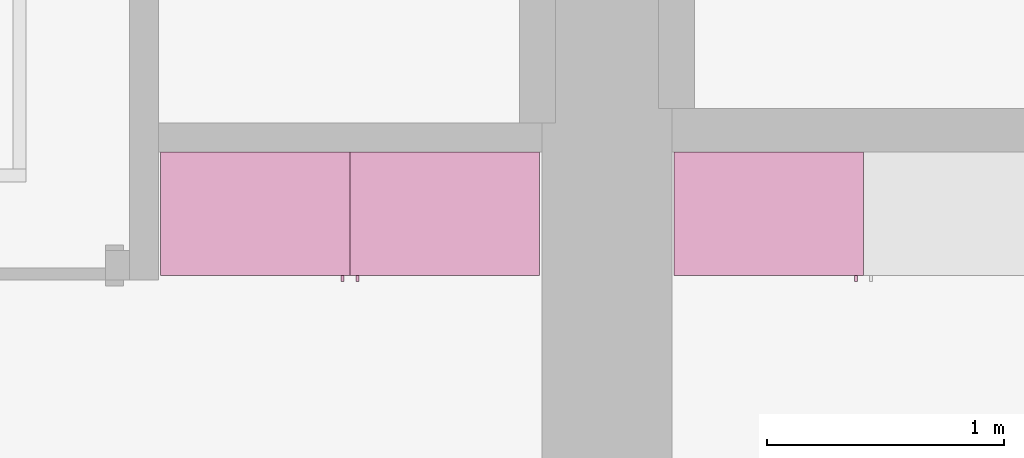
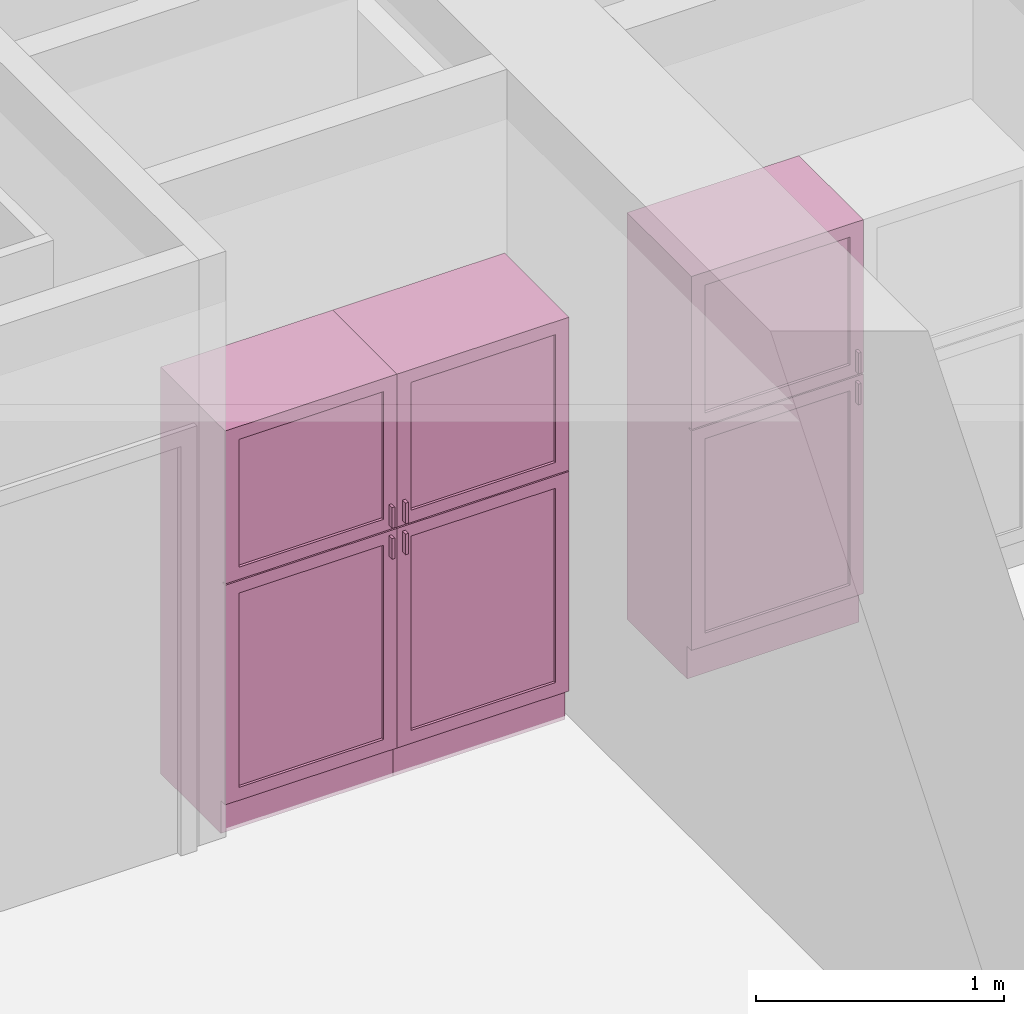
# One storey, part 14 of 16: 3 furnishings, 3 openings.
"""IFC2X3 building model written with IfcOpenShell, lengths in metres."""

import ifcopenshell
import ifcopenshell.guid

model = None  # the IFC model being written
_history = None  # IfcOwnerHistory: only IFC2X3 demands one
_inside = {}  # id of a spatial element -> (the spatial element, [elements in it])
_under = {}  # id of a project, library or spatial element -> (it, [spatial elements below it])
_declared = {}  # id of a project -> (the project, [libraries it declares])
_typed = {}  # id of a type object -> (the type object, [elements of that type])
_made_of = {}  # id of a material, layer set ... -> (it, [elements and type objects made of it])


def new_model(schema):
    """Start an empty IFC model of exactly this schema.

    Asked for "IFC4X3", IfcOpenShell would pick the latest addendum, in which some entities
    have other attributes; the version numbers below select the first issue.
    IFC2X3 requires an IfcOwnerHistory on every rooted entity: one is made here for all.
    """
    global model, _history
    if schema == "IFC4X3":
        model = ifcopenshell.file(schema_version=(4, 3, 0, 0))
    else:
        model = ifcopenshell.file(schema=schema)
    _inside.clear()
    _under.clear()
    _declared.clear()
    _typed.clear()
    _made_of.clear()
    _history = None
    if model.schema == "IFC2X3":
        org = make("IfcOrganization", Name="unknown")
        user = make(
            "IfcPersonAndOrganization",
            ThePerson=make("IfcPerson", FamilyName="unknown"),
            TheOrganization=org,
        )
        app = make(
            "IfcApplication",
            ApplicationDeveloper=org,
            Version="unknown",
            ApplicationFullName="unknown",
            ApplicationIdentifier="unknown",
        )
        _history = make(
            "IfcOwnerHistory",
            OwningUser=user,
            OwningApplication=app,
            ChangeAction="ADDED",
            CreationDate=0,
        )
    return model


def make(cls, **values):
    """One entity of the class cls with the attributes given. An attribute that is None is left unset."""
    return model.create_entity(
        cls, **{name: value for name, value in values.items() if value is not None}
    )


def entity(cls, *values):
    """Any entity or typed value of the class cls, its attributes in the order of the schema. None: left unset."""
    e = model.create_entity(cls)
    for i, value in enumerate(values):
        if value is not None:
            e[i] = value
    return e


def rooted(cls, **values):
    """An entity with a GlobalId (a new one), such as an element, a storey or a relation."""
    return make(cls, GlobalId=ifcopenshell.guid.new(), OwnerHistory=_history, **values)


def si_unit(unit_type, name, prefix=None):
    """IfcSIUnit, for example si_unit("LENGTHUNIT", "METRE", prefix="MILLI")."""
    return make("IfcSIUnit", UnitType=unit_type, Prefix=prefix, Name=name)


def converted_unit(unit_type, name, factor, base, dimensions=None, offset=None):
    """IfcConversionBasedUnit, such as the inch: factor (a typed value) times the base unit."""
    return make(
        "IfcConversionBasedUnit"
        if offset is None
        else "IfcConversionBasedUnitWithOffset",
        ConversionOffset=offset,
        Dimensions=None
        if dimensions is None
        else entity("IfcDimensionalExponents", *dimensions),
        UnitType=unit_type,
        Name=name,
        ConversionFactor=make(
            "IfcMeasureWithUnit", ValueComponent=factor, UnitComponent=base
        ),
    )


def assignment(units):
    """IfcUnitAssignment: the units of a project."""
    return None if units is None else make("IfcUnitAssignment", Units=units)


def point(xyz):
    """IfcCartesianPoint."""
    return None if xyz is None else make("IfcCartesianPoint", Coordinates=xyz)


def direction(xyz):
    """IfcDirection."""
    return None if xyz is None else make("IfcDirection", DirectionRatios=xyz)


def frame(location, z_axis=None, x_axis=None):
    """IfcAxis2Placement3D, a coordinate frame: its origin and axes. An axis left out is left unset."""
    return make(
        "IfcAxis2Placement3D",
        Location=point(location),
        Axis=direction(z_axis),
        RefDirection=direction(x_axis),
    )


def frame_2d(location, x_axis=None):
    """IfcAxis2Placement2D, a coordinate frame in the plane: its origin and x axis."""
    return make(
        "IfcAxis2Placement2D", Location=point(location), RefDirection=direction(x_axis)
    )


def origin():
    """The frame at (0, 0, 0) with its axes left unset."""
    return frame((0.0, 0.0, 0.0))


def origin_2d_with_axis():
    """The frame at (0, 0) in the plane with the x axis (1, 0) written out."""
    return frame_2d((0.0, 0.0), x_axis=(1.0, 0.0))


def place(relative_to, where):
    """IfcLocalPlacement: puts the frame where relative to a parent placement (None: the world)."""
    return make(
        "IfcLocalPlacement", PlacementRelTo=relative_to, RelativePlacement=where
    )


def context(
    kind, dimensions, precision=None, world=None, true_north=None, identifier=None
):
    """IfcGeometricRepresentationContext, for example the 3D "Model" context."""
    return make(
        "IfcGeometricRepresentationContext",
        ContextIdentifier=identifier,
        ContextType=kind,
        CoordinateSpaceDimension=dimensions,
        Precision=precision,
        WorldCoordinateSystem=world,
        TrueNorth=true_north,
    )


def project(units=None, contexts=None):
    """IfcProject with its units and contexts."""
    return rooted(
        "IfcProject",
        Name="project",
        RepresentationContexts=contexts,
        UnitsInContext=assignment(units),
    )


def spatial(cls, under=None, at=None, **own):
    """A site, building, storey or space (cls), placed at a placement, below another one or the project."""
    s = rooted(cls, ObjectPlacement=at, **own)
    if under is not None:
        _under.setdefault(under.id(), (under, []))[1].append(s)
    return s


def profile(cls, at=None, kind="AREA", **sizes):
    """A parametric profile (cls). Its sizes go by their IFC names, for example OverallWidth=200.0."""
    return make(cls, ProfileType=kind, Position=at, **sizes)


def rectangle(**sizes):
    """IfcRectangleProfileDef."""
    return profile("IfcRectangleProfileDef", **sizes)


def extrude(swept, where, along, depth):
    """IfcExtrudedAreaSolid: the profile swept, set in the frame where, extruded along a direction by depth."""
    return make(
        "IfcExtrudedAreaSolid",
        SweptArea=swept,
        Position=where,
        ExtrudedDirection=direction(along),
        Depth=depth,
    )


def faces_of(points, faces, orient=None, outer=None):
    """IfcFace entities. A face is a list of loops; a loop is a list of indices into points, from 0.

    orient and outer hold one flag for each loop. By default every Orientation is true, the
    first loop of a face is its IfcFaceOuterBound and the others are IfcFaceBound.
    """
    made = []
    for i, loops in enumerate(faces):
        bounds = []
        for j, loop in enumerate(loops):
            is_outer = j == 0 if outer is None else outer[i][j]
            bounds.append(
                make(
                    "IfcFaceOuterBound" if is_outer else "IfcFaceBound",
                    Bound=make("IfcPolyLoop", Polygon=[points[k] for k in loop]),
                    Orientation=True if orient is None else orient[i][j],
                )
            )
        made.append(make("IfcFace", Bounds=bounds))
    return made


def face_set(faces, orient=None, outer=None):
    """The faces of one IfcConnectedFaceSet. surface_model builds it on its shared points."""
    return ("IfcConnectedFaceSet", faces, orient, outer)


def surface_model(cls, points, shells):
    """IfcFaceBasedSurfaceModel or IfcShellBasedSurfaceModel (cls): surfaces that need not close."""
    shared = [point(p) for p in points]
    made = [make(c, CfsFaces=faces_of(shared, fs, o, b)) for c, fs, o, b in shells]
    if cls == "IfcFaceBasedSurfaceModel":
        return make(cls, FbsmFaces=made)
    return make(cls, SbsmBoundary=made)


def shape(context_of_items, identifier, shape_type, items):
    """IfcShapeRepresentation: the items that make up one representation, for example the "Body"."""
    return make(
        "IfcShapeRepresentation",
        ContextOfItems=context_of_items,
        RepresentationIdentifier=identifier,
        RepresentationType=shape_type,
        Items=items,
    )


def source(mapping_origin, context_of_items, identifier, shape_type, items):
    """IfcRepresentationMap: a shape defined once, which mapped items show again and again."""
    return make(
        "IfcRepresentationMap",
        MappingOrigin=mapping_origin,
        MappedRepresentation=shape(context_of_items, identifier, shape_type, items),
    )


def transform(
    local_origin,
    x_axis=None,
    y_axis=None,
    z_axis=None,
    scale=None,
    scale2=None,
    scale3=None,
    uniform=True,
):
    """IfcCartesianTransformationOperator3D, or its non-uniform kind. x_axis, y_axis, z_axis: its Axis1, 2, 3."""
    if uniform:
        return make(
            "IfcCartesianTransformationOperator3D",
            Axis1=direction(x_axis),
            Axis2=direction(y_axis),
            LocalOrigin=point(local_origin),
            Scale=scale,
            Axis3=direction(z_axis),
        )
    return make(
        "IfcCartesianTransformationOperator3DnonUniform",
        Axis1=direction(x_axis),
        Axis2=direction(y_axis),
        LocalOrigin=point(local_origin),
        Scale=scale,
        Axis3=direction(z_axis),
        Scale2=scale2,
        Scale3=scale3,
    )


def mapped(mapping_source, mapping_target):
    """IfcMappedItem: shows the shape of a source again, moved by a transform."""
    return make(
        "IfcMappedItem", MappingSource=mapping_source, MappingTarget=mapping_target
    )


def made_of(thing, what):
    """Note that an element or type object is made of a material, layer set ...; save() writes the relation."""
    if what is not None:
        _made_of.setdefault(what.id(), (what, []))[1].append(thing)
    return thing


def type_object(cls, material=None, **own):
    """A type object (cls), such as IfcWallType, which elements share."""
    return made_of(rooted(cls, **own), material)


def type_shapes(of_type, sources):
    """Give a type object the sources (RepresentationMaps) that its elements show as mapped items."""
    of_type.RepresentationMaps = sources


def element(
    cls,
    number,
    at=None,
    inside=None,
    cuts=None,
    type_object=None,
    material=None,
    context=None,
    identifier="Body",
    shape_type=None,
    held_by="IfcProductDefinitionShape",
    body=None,
    shapes=None,
    **own,
):
    """One element of the class cls, such as IfcWall. Its Tag is "e" and its number.

    at: its placement. inside: the storey or other place that contains it. cuts: it is an
    opening in that element (IfcRelVoidsElement). A single representation is given by context,
    identifier, shape_type and body (its items); several are given by shapes. held_by: the class
    of the entity that holds the representations. save() writes the other relations.
    """
    e = rooted(cls, Tag="e%d" % number, ObjectPlacement=at, **own)
    if body is not None:
        shapes = [shape(context, identifier, shape_type, body)]
    if shapes is not None:
        e.Representation = make(held_by, Representations=shapes)
    if inside is not None:
        _inside.setdefault(inside.id(), (inside, []))[1].append(e)
    if cuts is not None:
        rooted(
            "IfcRelVoidsElement", RelatingBuildingElement=cuts, RelatedOpeningElement=e
        )
    if type_object is not None:
        _typed.setdefault(type_object.id(), (type_object, []))[1].append(e)
    return made_of(e, material)


def aggregate(whole, parts):
    """IfcRelAggregates: a whole, such as a stair, and the parts it consists of."""
    return rooted("IfcRelAggregates", RelatingObject=whole, RelatedObjects=parts)


def save(model, path):
    """Write the relations noted so far, then the file.

    IfcRelAggregates (storeys below a building ...), IfcRelContainedInSpatialStructure (elements
    in a storey), IfcRelDefinesByType, IfcRelAssociatesMaterial and IfcRelDeclares: one each for
    every whole, place, type object, material and project.
    """
    for whole, parts in _under.values():
        aggregate(whole, parts)
    for where, things in _inside.values():
        rooted(
            "IfcRelContainedInSpatialStructure",
            RelatedElements=things,
            RelatingStructure=where,
        )
    for kind, things in _typed.values():
        rooted("IfcRelDefinesByType", RelatedObjects=things, RelatingType=kind)
    for what, things in _made_of.values():
        rooted("IfcRelAssociatesMaterial", RelatedObjects=things, RelatingMaterial=what)
    for by, libraries in _declared.values():
        rooted("IfcRelDeclares", RelatingContext=by, RelatedDefinitions=libraries)
    model.write(path)


model = new_model("IFC2X3")

# Units and contexts
model_context = context("Model", 3, precision=1e-09, world=origin())
plan_context = context("Plan", 3, precision=1e-09, world=origin())
ifc_project = project(units=[si_unit("LENGTHUNIT", "METRE"), si_unit("AREAUNIT", "SQUARE_METRE"), si_unit("VOLUMEUNIT", "CUBIC_METRE"), converted_unit("PLANEANGLEUNIT", "DEGREE", entity("IfcRatioMeasure", 0.01745329251994328), si_unit("PLANEANGLEUNIT", "RADIAN"), dimensions=[0, 0, 0, 0, 0, 0, 0]), si_unit("TIMEUNIT", "SECOND")], contexts=[model_context, plan_context])

# Site, building, storey, space
site_placement = place(None, origin())
site = spatial("IfcSite", under=ifc_project, at=site_placement, CompositionType="ELEMENT")
building_placement = place(site_placement, origin())
building = spatial("IfcBuilding", under=site, at=building_placement, CompositionType="ELEMENT")
storey_placement = place(building_placement, frame((0.0, 0.0, 3.100000000000378)))
storey = spatial("IfcBuildingStorey", under=building, at=storey_placement, Name="Level 2", CompositionType="ELEMENT", Elevation=3.100000000000378)
space_1_placement = place(storey_placement, origin())
space_1 = spatial("IfcSpace", under=storey, at=space_1_placement, CompositionType="ELEMENT", InteriorOrExteriorSpace="INTERNAL")

# Furnishing, opening
furniture_type_1 = type_object("IfcFurnitureType", Name="800 mm", AssemblyPlace="NOTDEFINED")
shared_shape_1 = source(origin(), model_context, "Body", "SurfaceModel", [
    surface_model("IfcFaceBasedSurfaceModel", [(0.7999999999999998, 0.04444999999999991, 0.1615874999998423), (0.0, 0.04445000000000255, 0.1615874999998423), (0.0, 0.04445000000000255, 2.0), (0.7999999999999998, 0.04444999999999991, 2.0), (0.7809499999999974, 0.04444999999999998, 1.980949999999954), (0.01904999999999817, 0.04445000000000248, 1.980949999999954), (0.01904999999999817, 0.04445000000000248, 0.1806374999998427), (0.7809499999999974, 0.04444999999999998, 0.1806374999998428), (0.0, 0.5454000000000022, 2.0), (0.8000000000000014, 0.5453999999999996, 2.0), (0.8000000000000026, 0.5453999999999996, 0.0), (0.0, 0.5454000000000009, 0.0), (0.780949999999999, 0.5453999999999996, 1.980949999999954), (0.0190499999999998, 0.5454000000000021, 1.980949999999954), (0.0190499999999998, 0.5454000000000021, 0.1806374999998428), (0.780949999999999, 0.5453999999999996, 0.1806374999998428), (0.7999999999999999, 0.06040000000000177, 0.1615874999998423), (0.7999999999999999, 0.06040000000000177, 0.0), (0.0, 0.06040000000000177, 0.0), (0.0, 0.06040000000000177, 0.1615874999998318), (0.7745999999999997, 0.0, 1.371548036695815), (0.7745999999999997, 0.0, 1.269948036695815), (0.7620677683693553, 0.0, 1.269948036695815), (0.7620677683693553, 0.0, 1.371548036695815), (0.7745999999999988, 0.0, 1.219148036695816), (0.7745999999999988, 0.0, 1.117548036695818), (0.7620677683693542, 0.0, 1.117548036695818), (0.7620677683693542, 0.0, 1.219148036695816), (0.7745999999999998, 0.02539999999999998, 1.371548036695815), (0.7745999999999998, 0.02539999999999998, 1.269948036695815), (0.7620677683693555, 0.02540000000000005, 1.269948036695815), (0.7620677683693555, 0.02540000000000005, 1.371548036695815), (0.7745999999999988, 0.02539999999999998, 1.219148036695816), (0.7745999999999988, 0.02539999999999998, 1.117548036695818), (0.7620677683693542, 0.02540000000000005, 1.117548036695818), (0.7620677683693542, 0.02540000000000005, 1.219148036695816), (0.7364999999999996, 0.03810000000000007, 1.936499999999956), (0.7364999999999996, 0.03810000000000007, 1.308048036695816), (0.06350000000000126, 0.03810000000000231, 1.308048036695816), (0.06350000000000126, 0.03810000000000231, 1.936499999999956), (0.736499999999999, 0.03810000000000007, 1.181048036695814), (0.736499999999999, 0.03810000000000007, 0.2250874999998395), (0.06350000000000072, 0.03810000000000231, 0.2250874999998395), (0.06350000000000072, 0.03810000000000231, 1.181048036695814), (0.7364999999999996, 0.04445000000000005, 1.936499999999956), (0.7364999999999996, 0.04445000000000005, 1.308048036695816), (0.06350000000000126, 0.04445000000000228, 1.308048036695816), (0.06350000000000126, 0.04445000000000228, 1.936499999999956), (0.736499999999999, 0.04445000000000005, 1.181048036695814), (0.736499999999999, 0.04445000000000005, 0.2250874999998395), (0.06350000000000072, 0.04445000000000228, 0.2250874999998395), (0.06350000000000072, 0.04445000000000228, 1.181048036695814), (0.8, 0.02539999999999984, 2.0), (0.8, 0.02539999999999984, 1.247723036695813), (0.0, 0.02540000000000248, 1.247723036695813), (0.0, 0.02540000000000248, 2.0), (0.7364999999999996, 0.02540000000000005, 1.936499999999956), (0.0635000000000012, 0.02540000000000228, 1.936499999999956), (0.0635000000000012, 0.02540000000000228, 1.308048036695816), (0.7364999999999996, 0.02540000000000005, 1.308048036695816), (0.7999999999999998, 0.02539999999999984, 0.1615874999998214), (0.0, 0.02540000000000248, 0.1615874999998214), (0.0, 0.02540000000000248, 1.241373036695815), (0.7999999999999998, 0.02539999999999984, 1.241373036695815), (0.736499999999999, 0.02540000000000005, 1.181048036695817), (0.06350000000000065, 0.02540000000000228, 1.181048036695817), (0.06350000000000065, 0.02540000000000228, 0.2250874999998395), (0.736499999999999, 0.02540000000000005, 0.2250874999998395), (0.8000000000000002, 0.04444999999999984, 2.0), (0.8000000000000002, 0.04444999999999984, 1.247723036695813), (0.0, 0.04445000000000248, 1.247723036695813), (0.0, 0.04445000000000248, 2.0), (0.7364999999999996, 0.04445000000000005, 1.936499999999956), (0.06350000000000126, 0.04445000000000228, 1.936499999999956), (0.06350000000000126, 0.04445000000000228, 1.308048036695816), (0.7364999999999996, 0.04445000000000005, 1.308048036695816), (0.7999999999999999, 0.04444999999999984, 0.1615874999998214), (0.0, 0.04445000000000248, 0.1615874999998214), (0.0, 0.04445000000000248, 1.241373036695815), (0.7999999999999999, 0.04444999999999984, 1.241373036695815), (0.736499999999999, 0.04445000000000005, 1.181048036695817), (0.06350000000000072, 0.04445000000000228, 1.181048036695817), (0.06350000000000072, 0.04445000000000228, 0.2250874999998395), (0.736499999999999, 0.04445000000000005, 0.2250874999998395), (0.7809499999999987, 0.5263500000000009, 1.980949999999952), (0.7809499999999988, 0.5263500000000009, 0.1806374999998463), (0.01904999999999987, 0.5263500000000009, 0.1806374999998463), (0.0190499999999998, 0.5263500000000009, 1.980949999999952), (0.7809499999999987, 0.5454000000000009, 1.980949999999952), (0.7809499999999987, 0.5454000000000009, 0.1806374999998463), (0.0190499999999998, 0.5454000000000009, 0.1806374999998463), (0.0190499999999998, 0.5454000000000009, 1.980949999999952)], [face_set([[[0, 1, 2, 3], [4, 5, 6, 7]], [[8, 9, 10, 11], [12, 13, 14, 15]], [[3, 0, 16, 17, 10, 9]], [[2, 8, 9, 3]], [[1, 2, 8, 11, 18, 19]], [[0, 1, 19, 16]], [[7, 15, 12, 4]], [[6, 14, 15, 7]], [[5, 13, 14, 6]], [[4, 5, 13, 12]], [[10, 17, 18, 11]], [[18, 19, 16, 17]]]), face_set([[[20, 21, 22, 23]], [[24, 25, 26, 27]], [[28, 29, 30, 31]], [[32, 33, 34, 35]], [[23, 31, 28, 20]], [[22, 23, 31, 30]], [[21, 22, 30, 29]], [[20, 28, 29, 21]], [[27, 35, 32, 24]], [[26, 27, 35, 34]], [[25, 26, 34, 33]], [[24, 32, 33, 25]]]), face_set([[[36, 37, 38, 39]], [[40, 41, 42, 43]], [[44, 45, 46, 47]], [[48, 49, 50, 51]], [[39, 47, 44, 36]], [[38, 46, 47, 39]], [[37, 38, 46, 45]], [[36, 37, 45, 44]], [[43, 51, 48, 40]], [[42, 50, 51, 43]], [[41, 42, 50, 49]], [[40, 41, 49, 48]]]), face_set([[[52, 53, 54, 55], [56, 57, 58, 59]], [[60, 61, 62, 63], [64, 65, 66, 67]], [[68, 69, 70, 71], [72, 73, 74, 75]], [[76, 77, 78, 79], [80, 81, 82, 83]], [[55, 71, 68, 52]], [[54, 55, 71, 70]], [[53, 54, 70, 69]], [[52, 53, 69, 68]], [[63, 60, 76, 79]], [[62, 78, 79, 63]], [[61, 62, 78, 77]], [[60, 61, 77, 76]], [[59, 75, 72, 56]], [[58, 74, 75, 59]], [[57, 58, 74, 73]], [[56, 57, 73, 72]], [[67, 83, 80, 64]], [[66, 82, 83, 67]], [[65, 66, 82, 81]], [[64, 65, 81, 80]]]), face_set([[[84, 85, 86, 87]], [[88, 89, 90, 91]], [[87, 91, 88, 84]], [[86, 87, 91, 90]], [[85, 86, 90, 89]], [[84, 85, 89, 88]]])]),
])
type_shapes(furniture_type_1, [shared_shape_1])
furnishing_1_placement = place(space_1_placement, frame((2.513999999999991, -11.6794, 0.0)))
furnishing_1 = element("IfcFurnishingElement", 1, at=furnishing_1_placement, inside=space_1, type_object=furniture_type_1, ObjectType="800 mm", context=model_context, shape_type="MappedRepresentation", body=[
    mapped(shared_shape_1, transform((0.0, 0.0, 0.0), scale=1.0)),
])
opening_1_placement = place(space_1_placement, frame((2.513999999999991, -11.6794, 0.0)))
element("IfcOpeningElement", 2, at=opening_1_placement, cuts=furnishing_1, ObjectType="Opening", context=model_context, shape_type="SweptSolid", body=[
    extrude(rectangle(XDim=1.800312500000111, YDim=0.7618999999999992, at=origin_2d_with_axis()), frame((0.01873770491802348, -0.5009499999999997, -2.01920625000048), z_axis=(0.0, 1.0, 0.0), x_axis=(0.0, 0.0, -1.0)), (0.0, 0.0, 1.0), 0.5009499999999997),
])

furniture_type_2 = type_object("IfcFurnitureType", Name="800 mm", AssemblyPlace="NOTDEFINED")
shared_shape_2 = source(origin(), model_context, "Body", "SurfaceModel", [
    surface_model("IfcFaceBasedSurfaceModel", [(0.7999999999999998, 0.5009500000000022, 0.1615874999998423), (0.7999999999999998, 0.5009500000000022, 2.0), (0.0, 0.5009499999999997, 2.0), (0.0, 0.5009499999999997, 0.1615874999998423), (0.7809499999999974, 0.5009500000000022, 1.980949999999954), (0.7809499999999974, 0.5009500000000022, 0.1806374999998428), (0.01904999999999817, 0.5009499999999997, 0.1806374999998428), (0.01904999999999817, 0.5009499999999997, 1.980949999999954), (0.0, 0.0, 2.0), (0.0, 0.0, 0.0), (0.8000000000000026, 0.0, 0.0), (0.8000000000000014, 0.0, 2.0), (0.780949999999999, 0.0, 1.980949999999954), (0.780949999999999, 0.0, 0.1806374999998428), (0.0190499999999998, 0.0, 0.1806374999998427), (0.0190499999999998, 0.0, 1.980949999999954), (0.8000000000000026, 0.4850000000000004, 0.0), (0.7999999999999999, 0.4850000000000004, 0.1615874999998318), (0.0, 0.4850000000000004, 0.0), (0.0, 0.4850000000000004, 0.1615874999998423), (0.7745999999999997, 0.5454000000000022, 1.371548036695815), (0.7620677683693553, 0.5454000000000021, 1.371548036695815), (0.7620677683693553, 0.5454000000000021, 1.269948036695815), (0.7745999999999997, 0.5454000000000022, 1.269948036695815), (0.7745999999999988, 0.5454000000000022, 1.219148036695816), (0.7620677683693542, 0.5454000000000021, 1.219148036695816), (0.7620677683693542, 0.5454000000000021, 1.117548036695818), (0.7745999999999988, 0.5454000000000022, 1.117548036695818), (0.7745999999999998, 0.5200000000000022, 1.371548036695815), (0.7620677683693555, 0.5200000000000021, 1.371548036695815), (0.7620677683693555, 0.5200000000000021, 1.269948036695815), (0.7745999999999998, 0.5200000000000022, 1.269948036695815), (0.7745999999999988, 0.5200000000000022, 1.219148036695816), (0.7620677683693542, 0.5200000000000021, 1.219148036695816), (0.7620677683693542, 0.5200000000000021, 1.117548036695818), (0.7745999999999988, 0.5200000000000022, 1.117548036695818), (0.7364999999999996, 0.5073000000000021, 1.936499999999956), (0.06350000000000126, 0.5072999999999999, 1.936499999999956), (0.06350000000000126, 0.5072999999999999, 1.308048036695816), (0.7364999999999996, 0.5073000000000021, 1.308048036695816), (0.736499999999999, 0.5073000000000021, 1.181048036695814), (0.06350000000000072, 0.5072999999999999, 1.181048036695814), (0.06350000000000072, 0.5072999999999999, 0.2250874999998395), (0.736499999999999, 0.5073000000000021, 0.2250874999998395), (0.7364999999999996, 0.5009500000000021, 1.936499999999956), (0.06350000000000126, 0.5009499999999999, 1.936499999999956), (0.06350000000000126, 0.5009499999999999, 1.308048036695816), (0.7364999999999996, 0.5009500000000021, 1.308048036695816), (0.736499999999999, 0.5009500000000021, 1.181048036695814), (0.06350000000000072, 0.5009499999999999, 1.181048036695814), (0.06350000000000072, 0.5009499999999999, 0.2250874999998395), (0.736499999999999, 0.5009500000000021, 0.2250874999998395), (0.8, 0.5200000000000023, 2.0), (0.0, 0.5199999999999997, 2.0), (0.0, 0.5199999999999997, 1.247723036695813), (0.8, 0.5200000000000023, 1.247723036695813), (0.7364999999999996, 0.5200000000000021, 1.936499999999956), (0.7364999999999996, 0.5200000000000021, 1.308048036695816), (0.0635000000000012, 0.5199999999999999, 1.308048036695816), (0.0635000000000012, 0.5199999999999999, 1.936499999999956), (0.7999999999999998, 0.5200000000000023, 0.1615874999998214), (0.7999999999999998, 0.5200000000000023, 1.241373036695815), (0.0, 0.5199999999999997, 1.241373036695815), (0.0, 0.5199999999999997, 0.1615874999998214), (0.736499999999999, 0.5200000000000021, 1.181048036695817), (0.736499999999999, 0.5200000000000021, 0.2250874999998395), (0.06350000000000065, 0.5199999999999999, 0.2250874999998395), (0.06350000000000065, 0.5199999999999999, 1.181048036695817), (0.8000000000000002, 0.5009500000000023, 2.0), (0.0, 0.5009499999999997, 2.0), (0.0, 0.5009499999999997, 1.247723036695813), (0.8, 0.5009500000000023, 1.247723036695813), (0.7364999999999996, 0.5009500000000021, 1.936499999999956), (0.7364999999999996, 0.5009500000000021, 1.308048036695816), (0.06350000000000126, 0.5009499999999999, 1.308048036695816), (0.06350000000000126, 0.5009499999999999, 1.936499999999956), (0.7999999999999999, 0.5009500000000023, 0.1615874999998214), (0.7999999999999999, 0.5009500000000023, 1.241373036695815), (0.0, 0.5009499999999997, 1.241373036695815), (0.0, 0.5009499999999997, 0.1615874999998214), (0.736499999999999, 0.5009500000000021, 1.181048036695817), (0.736499999999999, 0.5009500000000021, 0.2250874999998395), (0.06350000000000072, 0.5009499999999999, 0.2250874999998395), (0.06350000000000072, 0.5009499999999999, 1.181048036695817), (0.7809499999999987, 0.01905000000000129, 1.980949999999952), (0.0190499999999998, 0.01905000000000129, 1.980949999999952), (0.0190499999999998, 0.01905000000000129, 0.1806374999998463), (0.7809499999999987, 0.01905000000000129, 0.1806374999998463), (0.7809499999999987, 0.0, 1.980949999999952), (0.0190499999999998, 0.0, 1.980949999999952), (0.01904999999999987, 0.0, 0.1806374999998463), (0.7809499999999988, 0.0, 0.1806374999998463)], [face_set([[[0, 1, 2, 3], [4, 5, 6, 7]], [[8, 9, 10, 11], [12, 13, 14, 15]], [[1, 11, 10, 16, 17, 0]], [[2, 1, 11, 8]], [[3, 2, 8, 9, 18, 19]], [[0, 17, 19, 3]], [[5, 4, 12, 13]], [[6, 5, 13, 14]], [[7, 6, 14, 15]], [[4, 12, 15, 7]], [[10, 9, 18, 16]], [[18, 16, 17, 19]]]), face_set([[[20, 21, 22, 23]], [[24, 25, 26, 27]], [[28, 29, 30, 31]], [[32, 33, 34, 35]], [[21, 20, 28, 29]], [[22, 30, 29, 21]], [[23, 31, 30, 22]], [[20, 23, 31, 28]], [[25, 24, 32, 33]], [[26, 34, 33, 25]], [[27, 35, 34, 26]], [[24, 27, 35, 32]]]), face_set([[[36, 37, 38, 39]], [[40, 41, 42, 43]], [[44, 45, 46, 47]], [[48, 49, 50, 51]], [[37, 36, 44, 45]], [[38, 37, 45, 46]], [[39, 47, 46, 38]], [[36, 44, 47, 39]], [[41, 40, 48, 49]], [[42, 41, 49, 50]], [[43, 51, 50, 42]], [[40, 48, 51, 43]]]), face_set([[[52, 53, 54, 55], [56, 57, 58, 59]], [[60, 61, 62, 63], [64, 65, 66, 67]], [[68, 69, 70, 71], [72, 73, 74, 75]], [[76, 77, 78, 79], [80, 81, 82, 83]], [[53, 52, 68, 69]], [[54, 70, 69, 53]], [[55, 71, 70, 54]], [[52, 68, 71, 55]], [[61, 77, 76, 60]], [[62, 61, 77, 78]], [[63, 79, 78, 62]], [[60, 76, 79, 63]], [[57, 56, 72, 73]], [[58, 57, 73, 74]], [[59, 75, 74, 58]], [[56, 72, 75, 59]], [[65, 64, 80, 81]], [[66, 65, 81, 82]], [[67, 83, 82, 66]], [[64, 80, 83, 67]]]), face_set([[[84, 85, 86, 87]], [[88, 89, 90, 91]], [[85, 84, 88, 89]], [[86, 90, 89, 85]], [[87, 91, 90, 86]], [[84, 88, 91, 87]]])]),
])
type_shapes(furniture_type_2, [shared_shape_2])
furnishing_2_placement = place(space_1_placement, frame((4.113999999999993, -11.134, 0.0), z_axis=(0.0, 0.0, 1.0), x_axis=(-1.0, 0.0, 0.0)))
furnishing_2 = element("IfcFurnishingElement", 3, at=furnishing_2_placement, inside=space_1, type_object=furniture_type_2, ObjectType="800 mm", context=model_context, shape_type="MappedRepresentation", body=[
    mapped(shared_shape_2, transform((0.0, 0.0, 0.0), scale=1.0)),
])
opening_2_placement = place(space_1_placement, frame((4.113999999999993, -11.134, 0.0), z_axis=(0.0, 0.0, 1.0), x_axis=(-1.0, 0.0, 0.0)))
element("IfcOpeningElement", 4, at=opening_2_placement, cuts=furnishing_2, ObjectType="Opening", context=model_context, shape_type="SweptSolid", body=[
    extrude(rectangle(XDim=1.800312500000111, YDim=0.7618999999999992, at=origin_2d_with_axis()), frame((-0.01873770491802511, 0.0, -2.01920625000048), z_axis=(0.0, -1.0, 0.0), x_axis=(0.0, 0.0, -1.0)), (0.0, 0.0, 1.0), 0.5009499999999997),
])

# Space
space_2_placement = place(storey_placement, origin())
space_2 = spatial("IfcSpace", under=storey, at=space_2_placement, CompositionType="ELEMENT", InteriorOrExteriorSpace="INTERNAL")

# Furnishing, opening
furniture_type_3 = type_object("IfcFurnitureType", Name="800 mm", AssemblyPlace="NOTDEFINED")
shared_shape_3 = source(origin(), model_context, "Body", "SurfaceModel", [
    surface_model("IfcFaceBasedSurfaceModel", [(0.7999999999999998, 0.04444999999999991, 0.1615874999998423), (0.0, 0.04445000000000255, 0.1615874999998423), (0.0, 0.04445000000000255, 2.0), (0.7999999999999998, 0.04444999999999991, 2.0), (0.7809499999999974, 0.04444999999999998, 1.980949999999954), (0.01904999999999817, 0.04445000000000248, 1.980949999999954), (0.01904999999999817, 0.04445000000000248, 0.1806374999998427), (0.7809499999999974, 0.04444999999999998, 0.1806374999998428), (0.0, 0.5454000000000022, 2.0), (0.8000000000000014, 0.5453999999999996, 2.0), (0.8000000000000026, 0.5453999999999996, 0.0), (0.0, 0.5454000000000009, 0.0), (0.780949999999999, 0.5453999999999996, 1.980949999999954), (0.0190499999999998, 0.5454000000000021, 1.980949999999954), (0.0190499999999998, 0.5454000000000021, 0.1806374999998428), (0.780949999999999, 0.5453999999999996, 0.1806374999998428), (0.7999999999999999, 0.06040000000000177, 0.1615874999998423), (0.7999999999999999, 0.06040000000000177, 0.0), (0.0, 0.06040000000000177, 0.0), (0.0, 0.06040000000000177, 0.1615874999998318), (0.7745999999999997, 0.0, 1.371548036695815), (0.7745999999999997, 0.0, 1.269948036695815), (0.7620677683693553, 0.0, 1.269948036695815), (0.7620677683693553, 0.0, 1.371548036695815), (0.7745999999999988, 0.0, 1.219148036695816), (0.7745999999999988, 0.0, 1.117548036695818), (0.7620677683693542, 0.0, 1.117548036695818), (0.7620677683693542, 0.0, 1.219148036695816), (0.7745999999999998, 0.02539999999999998, 1.371548036695815), (0.7745999999999998, 0.02539999999999998, 1.269948036695815), (0.7620677683693555, 0.02540000000000005, 1.269948036695815), (0.7620677683693555, 0.02540000000000005, 1.371548036695815), (0.7745999999999988, 0.02539999999999998, 1.219148036695816), (0.7745999999999988, 0.02539999999999998, 1.117548036695818), (0.7620677683693542, 0.02540000000000005, 1.117548036695818), (0.7620677683693542, 0.02540000000000005, 1.219148036695816), (0.7364999999999996, 0.03810000000000007, 1.936499999999956), (0.7364999999999996, 0.03810000000000007, 1.308048036695816), (0.06350000000000126, 0.03810000000000231, 1.308048036695816), (0.06350000000000126, 0.03810000000000231, 1.936499999999956), (0.736499999999999, 0.03810000000000007, 1.181048036695814), (0.736499999999999, 0.03810000000000007, 0.2250874999998395), (0.06350000000000072, 0.03810000000000231, 0.2250874999998395), (0.06350000000000072, 0.03810000000000231, 1.181048036695814), (0.7364999999999996, 0.04445000000000005, 1.936499999999956), (0.7364999999999996, 0.04445000000000005, 1.308048036695816), (0.06350000000000126, 0.04445000000000228, 1.308048036695816), (0.06350000000000126, 0.04445000000000228, 1.936499999999956), (0.736499999999999, 0.04445000000000005, 1.181048036695814), (0.736499999999999, 0.04445000000000005, 0.2250874999998395), (0.06350000000000072, 0.04445000000000228, 0.2250874999998395), (0.06350000000000072, 0.04445000000000228, 1.181048036695814), (0.8, 0.02539999999999984, 2.0), (0.8, 0.02539999999999984, 1.247723036695813), (0.0, 0.02540000000000248, 1.247723036695813), (0.0, 0.02540000000000248, 2.0), (0.7364999999999996, 0.02540000000000005, 1.936499999999956), (0.0635000000000012, 0.02540000000000228, 1.936499999999956), (0.0635000000000012, 0.02540000000000228, 1.308048036695816), (0.7364999999999996, 0.02540000000000005, 1.308048036695816), (0.7999999999999998, 0.02539999999999984, 0.1615874999998214), (0.0, 0.02540000000000248, 0.1615874999998214), (0.0, 0.02540000000000248, 1.241373036695815), (0.7999999999999998, 0.02539999999999984, 1.241373036695815), (0.736499999999999, 0.02540000000000005, 1.181048036695817), (0.06350000000000065, 0.02540000000000228, 1.181048036695817), (0.06350000000000065, 0.02540000000000228, 0.2250874999998395), (0.736499999999999, 0.02540000000000005, 0.2250874999998395), (0.8000000000000002, 0.04444999999999984, 2.0), (0.8000000000000002, 0.04444999999999984, 1.247723036695813), (0.0, 0.04445000000000248, 1.247723036695813), (0.0, 0.04445000000000248, 2.0), (0.7364999999999996, 0.04445000000000005, 1.936499999999956), (0.06350000000000126, 0.04445000000000228, 1.936499999999956), (0.06350000000000126, 0.04445000000000228, 1.308048036695816), (0.7364999999999996, 0.04445000000000005, 1.308048036695816), (0.7999999999999999, 0.04444999999999984, 0.1615874999998214), (0.0, 0.04445000000000248, 0.1615874999998214), (0.0, 0.04445000000000248, 1.241373036695815), (0.7999999999999999, 0.04444999999999984, 1.241373036695815), (0.736499999999999, 0.04445000000000005, 1.181048036695817), (0.06350000000000072, 0.04445000000000228, 1.181048036695817), (0.06350000000000072, 0.04445000000000228, 0.2250874999998395), (0.736499999999999, 0.04445000000000005, 0.2250874999998395), (0.7809499999999987, 0.5263500000000009, 1.980949999999952), (0.7809499999999988, 0.5263500000000009, 0.1806374999998463), (0.01904999999999987, 0.5263500000000009, 0.1806374999998463), (0.0190499999999998, 0.5263500000000009, 1.980949999999952), (0.7809499999999987, 0.5454000000000009, 1.980949999999952), (0.7809499999999987, 0.5454000000000009, 0.1806374999998463), (0.0190499999999998, 0.5454000000000009, 0.1806374999998463), (0.0190499999999998, 0.5454000000000009, 1.980949999999952)], [face_set([[[0, 1, 2, 3], [4, 5, 6, 7]], [[8, 9, 10, 11], [12, 13, 14, 15]], [[3, 0, 16, 17, 10, 9]], [[2, 8, 9, 3]], [[1, 2, 8, 11, 18, 19]], [[0, 1, 19, 16]], [[7, 15, 12, 4]], [[6, 14, 15, 7]], [[5, 13, 14, 6]], [[4, 5, 13, 12]], [[10, 17, 18, 11]], [[18, 19, 16, 17]]]), face_set([[[20, 21, 22, 23]], [[24, 25, 26, 27]], [[28, 29, 30, 31]], [[32, 33, 34, 35]], [[23, 31, 28, 20]], [[22, 23, 31, 30]], [[21, 22, 30, 29]], [[20, 28, 29, 21]], [[27, 35, 32, 24]], [[26, 27, 35, 34]], [[25, 26, 34, 33]], [[24, 32, 33, 25]]]), face_set([[[36, 37, 38, 39]], [[40, 41, 42, 43]], [[44, 45, 46, 47]], [[48, 49, 50, 51]], [[39, 47, 44, 36]], [[38, 46, 47, 39]], [[37, 38, 46, 45]], [[36, 37, 45, 44]], [[43, 51, 48, 40]], [[42, 50, 51, 43]], [[41, 42, 50, 49]], [[40, 41, 49, 48]]]), face_set([[[52, 53, 54, 55], [56, 57, 58, 59]], [[60, 61, 62, 63], [64, 65, 66, 67]], [[68, 69, 70, 71], [72, 73, 74, 75]], [[76, 77, 78, 79], [80, 81, 82, 83]], [[55, 71, 68, 52]], [[54, 55, 71, 70]], [[53, 54, 70, 69]], [[52, 53, 69, 68]], [[63, 60, 76, 79]], [[62, 78, 79, 63]], [[61, 62, 78, 77]], [[60, 61, 77, 76]], [[59, 75, 72, 56]], [[58, 74, 75, 59]], [[57, 58, 74, 73]], [[56, 57, 73, 72]], [[67, 83, 80, 64]], [[66, 82, 83, 67]], [[65, 66, 82, 81]], [[64, 65, 81, 80]]]), face_set([[[84, 85, 86, 87]], [[88, 89, 90, 91]], [[87, 91, 88, 84]], [[86, 87, 91, 90]], [[85, 86, 90, 89]], [[84, 85, 89, 88]]])]),
])
type_shapes(furniture_type_3, [shared_shape_3])
furnishing_3_placement = place(space_2_placement, frame((4.682999999999983, -11.67940000000001, 0.0)))
furnishing_3 = element("IfcFurnishingElement", 5, at=furnishing_3_placement, inside=space_2, type_object=furniture_type_3, ObjectType="800 mm", context=model_context, shape_type="MappedRepresentation", body=[
    mapped(shared_shape_3, transform((0.0, 0.0, 0.0), scale=1.0)),
])
opening_3_placement = place(space_2_placement, frame((4.682999999999983, -11.67940000000001, 0.0)))
element("IfcOpeningElement", 6, at=opening_3_placement, cuts=furnishing_3, ObjectType="Opening", context=model_context, shape_type="SweptSolid", body=[
    extrude(rectangle(XDim=1.800312500000111, YDim=0.7618999999999992, at=origin_2d_with_axis()), frame((0.01873770491802348, -0.5009499999999997, -2.01920625000048), z_axis=(0.0, 1.0, 0.0), x_axis=(0.0, 0.0, -1.0)), (0.0, 0.0, 1.0), 0.5009499999999997),
])

save(model, "model.ifc")
